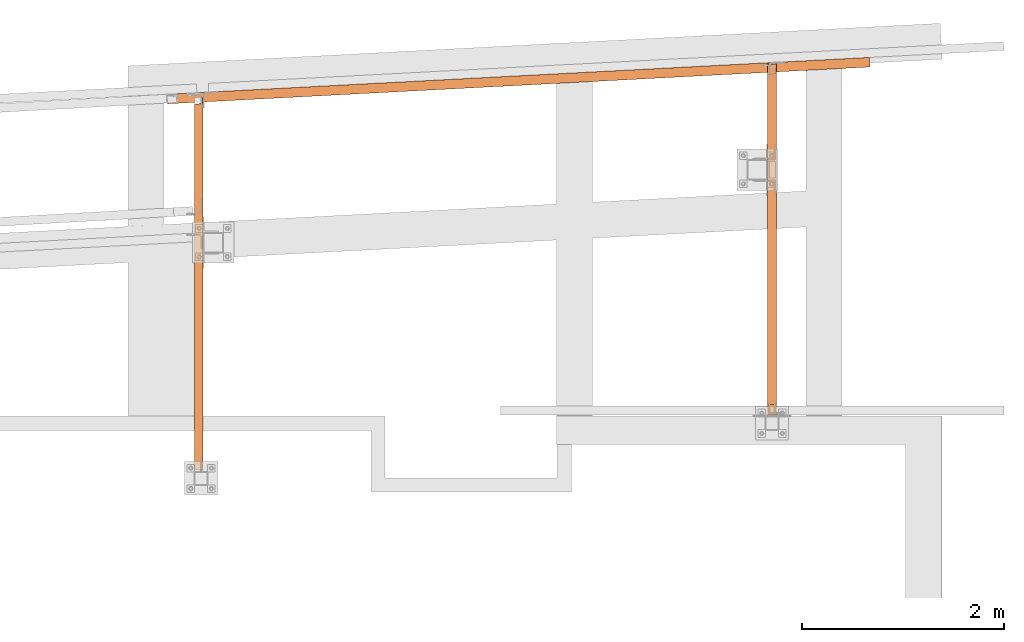
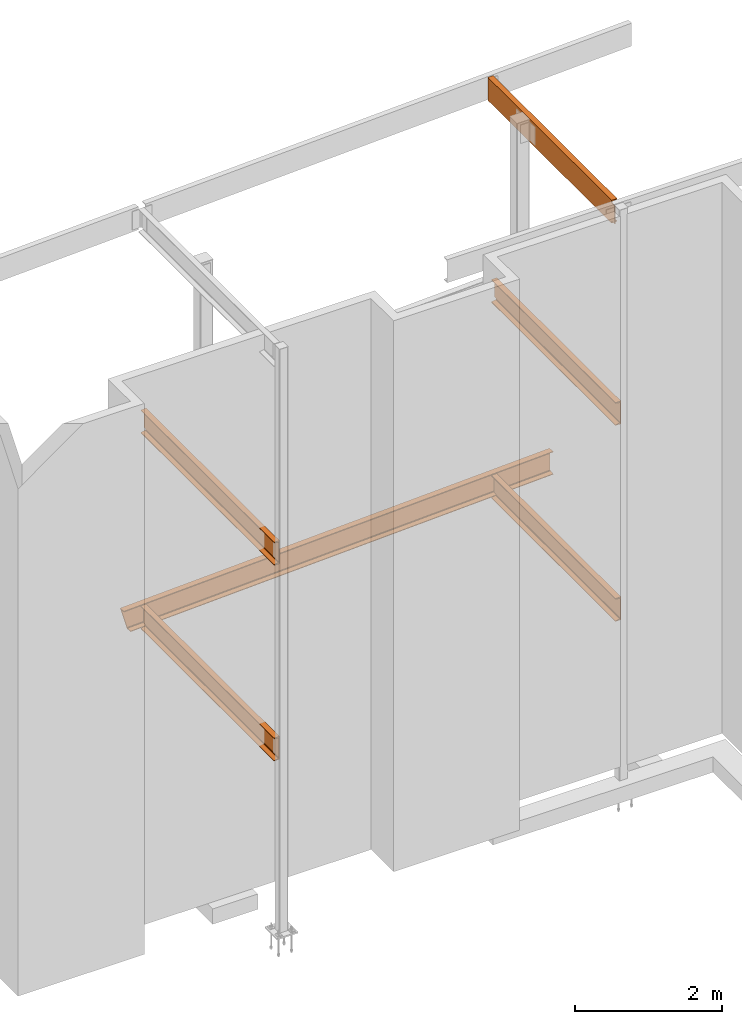
# One storey, part 20 of 89: 6 proxies.
"""IFC4 building model written with IfcOpenShell, lengths in feet."""

from ifc_helpers import new_model, entity, si_unit, converted_unit, derived_unit, direction, frame, origin, place, context, subcontext, project, spatial, faceted_brep, source, transform, mapped, material, constituent, constituent_set, type_object, type_shapes, element, save


model = new_model("IFC4")

# Units and contexts
model_context = context("Model", 3, precision=0.0001, world=origin(), true_north=direction((6.12303176911189e-17, 1.0)))
body_context = subcontext(model_context, "Body", "Model", "MODEL_VIEW")
ifc_project = project(units=[converted_unit("LENGTHUNIT", "FOOT", entity("IfcRatioMeasure", 0.3048), si_unit("LENGTHUNIT", "METRE"), dimensions=[1, 0, 0, 0, 0, 0, 0]), converted_unit("AREAUNIT", "SQUARE FOOT", entity("IfcRatioMeasure", 0.09290304), si_unit("AREAUNIT", "SQUARE_METRE"), dimensions=[2, 0, 0, 0, 0, 0, 0]), converted_unit("VOLUMEUNIT", "CUBIC FOOT", entity("IfcRatioMeasure", 0.028316846592), si_unit("VOLUMEUNIT", "CUBIC_METRE"), dimensions=[3, 0, 0, 0, 0, 0, 0]), si_unit("PLANEANGLEUNIT", "RADIAN"), si_unit("MASSUNIT", "GRAM", prefix="KILO"), derived_unit("MASSDENSITYUNIT", [(si_unit("MASSUNIT", "GRAM", prefix="KILO"), 1), (si_unit("LENGTHUNIT", "METRE"), -3)]), derived_unit("MOMENTOFINERTIAUNIT", [(si_unit("LENGTHUNIT", "METRE"), 4)]), si_unit("TIMEUNIT", "SECOND"), si_unit("FREQUENCYUNIT", "HERTZ"), si_unit("THERMODYNAMICTEMPERATUREUNIT", "DEGREE_CELSIUS"), derived_unit("THERMALTRANSMITTANCEUNIT", [(si_unit("MASSUNIT", "GRAM", prefix="KILO"), 1), (si_unit("THERMODYNAMICTEMPERATUREUNIT", "KELVIN"), -1), (si_unit("TIMEUNIT", "SECOND"), -3)]), derived_unit("VOLUMETRICFLOWRATEUNIT", [(si_unit("LENGTHUNIT", "METRE"), 3), (si_unit("TIMEUNIT", "SECOND"), -1)]), si_unit("ELECTRICCURRENTUNIT", "AMPERE"), si_unit("ELECTRICVOLTAGEUNIT", "VOLT"), si_unit("POWERUNIT", "WATT"), si_unit("FORCEUNIT", "NEWTON"), si_unit("ILLUMINANCEUNIT", "LUX"), si_unit("LUMINOUSFLUXUNIT", "LUMEN"), si_unit("LUMINOUSINTENSITYUNIT", "CANDELA"), derived_unit("USERDEFINED", [(si_unit("MASSUNIT", "GRAM", prefix="KILO"), -1), (si_unit("LENGTHUNIT", "METRE"), -2), (si_unit("TIMEUNIT", "SECOND"), 3), (si_unit("LUMINOUSFLUXUNIT", "LUMEN"), 1)]), derived_unit("LINEARVELOCITYUNIT", [(si_unit("LENGTHUNIT", "METRE"), 1), (si_unit("TIMEUNIT", "SECOND"), -1)]), si_unit("PRESSUREUNIT", "PASCAL"), derived_unit("USERDEFINED", [(si_unit("LENGTHUNIT", "METRE"), -2), (si_unit("MASSUNIT", "GRAM", prefix="KILO"), 1), (si_unit("TIMEUNIT", "SECOND"), -2)]), derived_unit("LINEARFORCEUNIT", [(si_unit("MASSUNIT", "GRAM", prefix="KILO"), 1), (si_unit("LENGTHUNIT", "METRE"), 1), (si_unit("TIMEUNIT", "SECOND"), -2), (si_unit("LENGTHUNIT", "METRE"), -1)]), derived_unit("PLANARFORCEUNIT", [(si_unit("MASSUNIT", "GRAM", prefix="KILO"), 1), (si_unit("LENGTHUNIT", "METRE"), 1), (si_unit("TIMEUNIT", "SECOND"), -2), (si_unit("LENGTHUNIT", "METRE"), -2)])], contexts=[model_context])

# Site, building, storey
site_placement = place(None, origin())
site = spatial("IfcSite", under=ifc_project, at=site_placement, CompositionType="ELEMENT")
building_placement = place(site_placement, frame((-472.238160486, -49.138065117, 0.0)))
building = spatial("IfcBuilding", under=site, at=building_placement, CompositionType="ELEMENT")
storey_placement = place(building_placement, origin())
storey = spatial("IfcBuildingStorey", under=building, at=storey_placement, Name="Level 1", CompositionType="ELEMENT", Elevation=0.0)

# Proxies
ifc_material_1 = material(Name="Color 7720", Category="Materials")
ifc_material_2 = material()
ifc_constituent_1 = constituent(ifc_material_2)
ifc_constituent_2 = constituent(ifc_material_1, Name="Color 7720", Category="Materials")
ifc_constituent_set_1 = constituent_set(constituents=[ifc_constituent_1, ifc_constituent_2])
building_element_proxy_type_1 = type_object("IfcBuildingElementProxyType", Name="17B1", PredefinedType="NOTDEFINED", material=ifc_constituent_set_1)
shared_shape_1 = source(origin(), body_context, "Body", "Brep", [
    faceted_brep([(0.0, 0.309575155774041, 1.25), (0.357523018910797, 0.328312143237781, 0.0), (0.373747165346117, 0.0187369874638534, 0.0), (0.364220956214638, 0.0182377399981988, 0.0333062789933916), (0.343602348434274, 0.223617862109904, 0.0676680457191132), (0.340924744883921, 0.240912802348817, 0.0738437414016779), (0.336807802828389, 0.254938044365076, 0.085635454312385), (0.331754718383309, 0.263979343166852, 0.101601934112377), (0.326383108321011, 0.26693161969888, 0.119791666666666), (0.0373853347014688, 0.251785888165614, 1.13020833333333), (0.0323517478101394, 0.248288298368493, 1.14839806588763), (0.0282714177600951, 0.238768337595729, 1.16436454568762), (0.0256430657388478, 0.224389589696102, 1.17615625859832), (0.0247879439063468, 0.206909507165051, 1.18233195428089), (0.0257503555668563, 0.000499247465654662, 1.21669372100661), (0.0162241464353201, 0.0, 1.25), (22.8188993104869, 1.19503756706081, 1.25), (22.8188993104869, 1.19503756706081, 1.2166937210066), (22.8081088007665, 1.40093275796642, 1.18233195428088), (22.8071975599075, 1.41832026935128, 1.17615625859831), (22.8064532648904, 1.43252226430934, 1.16436454568762), (22.8059668876929, 1.44180289409644, 1.14839806588763), (22.8057978761074, 1.44502782726101, 1.13020833333333), (22.8057978761074, 1.44502782726101, 0.119791666666671), (22.8059668876929, 1.44180289409644, 0.101601934112372), (22.8064532648904, 1.43252226430934, 0.0856354543123814), (22.8071975599075, 1.41832026935128, 0.0738437414016921), (22.8081088007665, 1.40093275796642, 0.0676680457191221), (22.8188993104869, 1.19503756706081, 0.0333062789934022), (22.8188993104869, 1.19503756706081, 0.0), (22.8026751640516, 1.50461272283474, 0.0), (22.8026751640516, 1.50461272283474, 1.25)], [[[0, 1, 2, 3, 4, 5, 6, 7, 8, 9, 10, 11, 12, 13, 14, 15]], [[16, 17, 18, 19, 20, 21, 22, 23, 24, 25, 26, 27, 28, 29, 30, 31]], [[30, 1, 0, 31]], [[29, 2, 1, 30]], [[28, 3, 2, 29]], [[27, 4, 3, 28]], [[26, 5, 4, 27]], [[25, 6, 5, 26]], [[24, 7, 6, 25]], [[23, 8, 7, 24]], [[22, 9, 8, 23]], [[21, 10, 9, 22]], [[20, 11, 10, 21]], [[19, 12, 11, 20]], [[18, 13, 12, 19]], [[17, 14, 13, 18]], [[16, 15, 14, 17]], [[31, 0, 15, 16]]]),
])
type_shapes(building_element_proxy_type_1, [shared_shape_1])
proxy_1_placement = place(building_placement, frame((306.666666666667, 1018.1412206105, 8.35416666666667)))
element("IfcBuildingElementProxy", 1, at=proxy_1_placement, inside=storey, type_object=building_element_proxy_type_1, material=ifc_material_1, Name="17B1:17B1", ObjectType="17B1:17B1", PredefinedType="NOTDEFINED", context=body_context, shape_type="MappedRepresentation", body=[
    mapped(shared_shape_1, transform((0.0, 0.0, 0.0), scale=1.0)),
])
ifc_constituent_3 = constituent(ifc_material_2)
ifc_constituent_4 = constituent(ifc_material_1, Name="Color 7720", Category="Materials")
ifc_constituent_set_2 = constituent_set(constituents=[ifc_constituent_3, ifc_constituent_4])
building_element_proxy_type_2 = type_object("IfcBuildingElementProxyType", Name="c749", PredefinedType="NOTDEFINED", material=ifc_constituent_set_2)
shared_shape_2 = source(origin(), body_context, "Body", "Brep", [
    faceted_brep([(0.0, 0.0, 1.25), (0.0, 0.0, 1.21666594419212), (0.205817018106757, 0.0, 1.18236429742145), (0.223239195075223, 0.0, 1.17618476966831), (0.237469504634021, 0.0, 1.16438573990164), (0.24676863726728, 0.0, 1.14840935276805), (0.249999999999943, 0.0, 1.13020833333334), (0.249999999999943, 0.0, 0.119791666666673), (0.24676863726728, 0.0, 0.101590647231953), (0.237469504634021, 0.0, 0.0856142600983727), (0.223239195075223, 0.0, 0.073815230331693), (0.205817018106757, 0.0, 0.0676357025785528), (0.0, 0.0, 0.0333340558078827), (0.0, 0.0, 0.0), (0.283333333333303, 0.0, 0.0), (0.283333333333303, 0.0, 1.25), (0.249999999999943, 11.2792629997535, 0.125000000000004), (0.249999999999943, 11.2792629997535, 1.125), (0.283333333333303, 11.2792629997535, 1.125), (0.283333333333303, 11.2792629997535, 0.125000000000004), (0.0, 11.0664753261987, 1.21666594419212), (0.0, 11.0664753261987, 1.25), (0.184374999999989, 11.0761379997535, 1.18593784317542), (0.205817018106757, 11.0761379997535, 1.18236429742146), (0.223239195075223, 11.0761379997535, 1.17618476966831), (0.237469504634021, 11.0765917042962, 1.16438573990166), (0.234718575567001, 11.0761379997535, 1.16666666666671), (0.24676863726728, 11.0808546290905, 1.14840935276807), (0.24542282713287, 11.0793096858989, 1.15072152365148), (0.249999999999943, 11.098811465487, 1.13020833333334), (0.248758027692929, 11.0883418838708, 1.13720388411723), (0.249999999999943, 11.101859523405, 0.121828313854644), (0.249999999999943, 11.098811465487, 0.119791666666673), (0.249999999999943, 11.101859523405, 1.12817168614537), (0.249999999999943, 11.1178046664203, 1.125), (0.249999999999943, 11.1178046664203, 0.125000000000004), (0.24676863726728, 11.0808546290905, 0.101590647231946), (0.248758027692929, 11.0883418838708, 0.11279611588277), (0.237469504634021, 11.0765917042962, 0.0856142600983567), (0.24542282713287, 11.0793096858989, 0.0992784763485322), (0.223239195075223, 11.0761379997535, 0.0738152303316753), (0.234718575567001, 11.0761379997535, 0.0833333333332966), (0.205817018106757, 11.0761379997535, 0.0676357025785528), (0.0, 11.0664753261987, 0.033334055807881), (0.184374999999989, 11.0761379997535, 0.0640621568245905), (0.0, 11.0664753261987, 0.0), (0.184374999999989, 11.0761379997535, 0.0), (0.283333333333303, 11.0761379997535, 0.0), (0.283333333333246, 11.0793096858989, 0.0992784763485535), (0.283333333333246, 11.0883418838708, 0.112796115882773), (0.283333333333246, 11.101859523405, 0.121828313854644), (0.283333333333246, 11.1178046664203, 0.125000000000004), (0.283333333333246, 11.1178046664203, 1.125), (0.283333333333246, 11.101859523405, 1.12817168614537), (0.283333333333246, 11.0883418838708, 1.13720388411723), (0.283333333333246, 11.0793096858989, 1.15072152365146), (0.283333333333246, 11.0761379997535, 1.16666666666667), (0.283333333333246, 11.0761379997535, 1.25), (0.283333333333246, 11.0761379997535, 0.0833333333333339), (0.184374999999989, 11.0761379997535, 1.25000000000001)], [[[0, 1, 2, 3, 4, 5, 6, 7, 8, 9, 10, 11, 12, 13, 14, 15]], [[16, 17, 18, 19]], [[20, 1, 0, 21]], [[22, 23, 2, 1, 20]], [[24, 3, 2, 23]], [[25, 4, 3, 24, 26]], [[27, 5, 4, 25, 28]], [[29, 6, 5, 27, 30]], [[31, 32, 7, 6, 29, 33, 34, 17, 16, 35]], [[36, 8, 7, 32, 37]], [[38, 9, 8, 36, 39]], [[40, 10, 9, 38, 41]], [[42, 11, 10, 40]], [[43, 12, 11, 42, 44]], [[45, 13, 12, 43]], [[46, 47, 14, 13, 45]], [[48, 49, 50, 51, 19, 18, 52, 53, 54, 55, 56, 57, 15, 14, 47, 58]], [[21, 0, 15, 57, 59]], [[59, 57, 56, 26, 24, 23, 22]], [[26, 56, 55, 28, 25]], [[28, 55, 54, 30, 27]], [[30, 54, 53, 33, 29]], [[33, 53, 52, 34]], [[17, 34, 52, 18]], [[59, 22, 20, 21]], [[19, 51, 35, 16]], [[50, 31, 35, 51]], [[31, 50, 49, 37, 32]], [[37, 49, 48, 39, 36]], [[39, 48, 58, 41, 38]], [[44, 46, 47, 58, 41, 40, 42]], [[45, 43, 44, 46]]]),
])
type_shapes(building_element_proxy_type_2, [shared_shape_2])
proxy_2_placement = place(building_placement, frame((326.166666666667, 1008.04166666666, 8.35416666666666)))
element("IfcBuildingElementProxy", 2, at=proxy_2_placement, inside=storey, type_object=building_element_proxy_type_2, material=ifc_material_1, Name="c749:c749", ObjectType="c749:c749", PredefinedType="NOTDEFINED", context=body_context, shape_type="MappedRepresentation", body=[
    mapped(shared_shape_2, transform((0.0, 0.0, 0.0), scale=1.0)),
])
ifc_constituent_5 = constituent(ifc_material_2)
ifc_constituent_6 = constituent(ifc_material_1, Name="Color 7720", Category="Materials")
ifc_constituent_set_3 = constituent_set(constituents=[ifc_constituent_5, ifc_constituent_6])
building_element_proxy_type_3 = type_object("IfcBuildingElementProxyType", Name="c748", PredefinedType="NOTDEFINED", material=ifc_constituent_set_3)
shared_shape_3 = source(origin(), body_context, "Body", "Brep", [
    faceted_brep([(0.0, 0.0, 1.25), (0.0, 0.0, 1.21666594419212), (0.205817018106814, 0.0, 1.18236429742145), (0.22323919507528, 0.0, 1.17618476966831), (0.237469504634078, 0.0, 1.16438573990164), (0.246768637267337, 0.0, 1.14840935276805), (0.25, 0.0, 1.13020833333334), (0.25, 0.0, 0.119791666666673), (0.246768637267337, 0.0, 0.101590647231953), (0.237469504634078, 0.0, 0.0856142600983727), (0.22323919507528, 0.0, 0.073815230331693), (0.205817018106814, 0.0, 0.0676357025785528), (0.0, 0.0, 0.0333340558078827), (0.0, 0.0, 0.0), (0.28333333333336, 0.0, 0.0), (0.28333333333336, 0.0, 1.25), (0.25, 12.0952715087674, 0.125000000000004), (0.25, 12.0952715087674, 1.125), (0.28333333333336, 12.0952715087674, 1.125), (0.28333333333336, 12.0952715087674, 0.125000000000004), (0.0, 11.8824838352124, 1.21666594419212), (0.0, 11.8824838352124, 1.25), (0.184375000000045, 11.8921465087674, 1.18593784317542), (0.205817018106814, 11.8921465087674, 1.18236429742146), (0.22323919507528, 11.8921465087674, 1.17618476966831), (0.237469504634078, 11.8926002133099, 1.16438573990166), (0.234718575567058, 11.8921465087674, 1.16666666666671), (0.246768637267337, 11.8968631381042, 1.14840935276807), (0.245422827132927, 11.8953181949128, 1.15072152365148), (0.25, 11.9148199745007, 1.13020833333334), (0.248758027692986, 11.9043503928847, 1.13720388411723), (0.250000000000057, 11.9178680324187, 0.121828313854644), (0.250000000000057, 11.9148199745007, 0.119791666666673), (0.250000000000057, 11.9178680324187, 1.12817168614537), (0.250000000000057, 11.933813175434, 1.125), (0.250000000000057, 11.933813175434, 0.125000000000004), (0.246768637267337, 11.8968631381042, 0.101590647231946), (0.248758027692986, 11.9043503928847, 0.11279611588277), (0.237469504634078, 11.8926002133099, 0.0856142600983567), (0.245422827132927, 11.8953181949128, 0.0992784763485322), (0.22323919507528, 11.8921465087674, 0.0738152303316753), (0.234718575567058, 11.8921465087674, 0.0833333333332966), (0.205817018106814, 11.8921465087674, 0.0676357025785528), (0.0, 11.8824838352124, 0.033334055807881), (0.184375000000045, 11.8921465087674, 0.0640621568245905), (0.0, 11.8824838352124, 0.0), (0.184375000000045, 11.8921465087674, 0.0), (0.28333333333336, 11.8921465087674, 0.0), (0.283333333333417, 11.8953181949128, 0.0992784763485535), (0.283333333333417, 11.9043503928847, 0.112796115882773), (0.283333333333417, 11.9178680324187, 0.121828313854644), (0.283333333333417, 11.933813175434, 0.125000000000004), (0.283333333333417, 11.933813175434, 1.125), (0.283333333333417, 11.9178680324187, 1.12817168614537), (0.283333333333417, 11.9043503928847, 1.13720388411723), (0.283333333333417, 11.8953181949128, 1.15072152365146), (0.283333333333417, 11.8921465087674, 1.16666666666667), (0.283333333333417, 11.8921465087674, 1.25), (0.283333333333417, 11.8921465087674, 0.0833333333333339), (0.184375000000045, 11.8921465087674, 1.25000000000001)], [[[0, 1, 2, 3, 4, 5, 6, 7, 8, 9, 10, 11, 12, 13, 14, 15]], [[16, 17, 18, 19]], [[20, 1, 0, 21]], [[22, 23, 2, 1, 20]], [[24, 3, 2, 23]], [[25, 4, 3, 24, 26]], [[27, 5, 4, 25, 28]], [[29, 6, 5, 27, 30]], [[31, 32, 7, 6, 29, 33, 34, 17, 16, 35]], [[36, 8, 7, 32, 37]], [[38, 9, 8, 36, 39]], [[40, 10, 9, 38, 41]], [[42, 11, 10, 40]], [[43, 12, 11, 42, 44]], [[45, 13, 12, 43]], [[46, 47, 14, 13, 45]], [[48, 49, 50, 51, 19, 18, 52, 53, 54, 55, 56, 57, 15, 14, 47, 58]], [[21, 0, 15, 57, 59]], [[59, 57, 56, 26, 24, 23, 22]], [[26, 56, 55, 28, 25]], [[28, 55, 54, 30, 27]], [[30, 54, 53, 33, 29]], [[33, 53, 52, 34]], [[17, 34, 52, 18]], [[59, 22, 20, 21]], [[19, 51, 35, 16]], [[50, 31, 35, 51]], [[31, 50, 49, 37, 32]], [[37, 49, 48, 39, 36]], [[39, 48, 58, 41, 38]], [[44, 46, 47, 58, 41, 40, 42]], [[45, 43, 44, 46]]]),
])
type_shapes(building_element_proxy_type_3, [shared_shape_3])
proxy_3_placement = place(building_placement, frame((307.55, 1006.25, 8.35416666666666)))
element("IfcBuildingElementProxy", 3, at=proxy_3_placement, inside=storey, type_object=building_element_proxy_type_3, material=ifc_material_1, Name="c748:c748", ObjectType="c748:c748", PredefinedType="NOTDEFINED", context=body_context, shape_type="MappedRepresentation", body=[
    mapped(shared_shape_3, transform((0.0, 0.0, 0.0), scale=1.0)),
])
ifc_constituent_7 = constituent(ifc_material_2)
ifc_constituent_8 = constituent(ifc_material_1, Name="Color 7720", Category="Materials")
ifc_constituent_set_4 = constituent_set(constituents=[ifc_constituent_7, ifc_constituent_8])
building_element_proxy_type_4 = type_object("IfcBuildingElementProxyType", Name="c750", PredefinedType="NOTDEFINED", material=ifc_constituent_set_4)
shared_shape_4 = source(origin(), body_context, "Body", "Brep", [
    faceted_brep([(0.0, 0.0, 1.25), (0.0, 0.0, 1.21666594419212), (0.205817018106757, 0.0, 1.18236429742145), (0.223239195075223, 0.0, 1.17618476966831), (0.237469504634021, 0.0, 1.16438573990164), (0.24676863726728, 0.0, 1.14840935276806), (0.249999999999943, 0.0, 1.13020833333334), (0.249999999999943, 0.0, 0.119791666666675), (0.24676863726728, 0.0, 0.101590647231955), (0.237469504634021, 0.0, 0.0856142600983745), (0.223239195075223, 0.0, 0.073815230331693), (0.205817018106757, 0.0, 0.0676357025785528), (0.0, 0.0, 0.0333340558078845), (0.0, 0.0, 0.0), (0.283333333333303, 0.0, 0.0), (0.283333333333303, 0.0, 1.25), (0.249999999999943, 11.219927776912, 0.125000000000004), (0.249999999999943, 11.219927776912, 1.125), (0.283333333333303, 11.219927776912, 1.125), (0.283333333333303, 11.219927776912, 0.125000000000004), (0.0, 11.0644317700238, 1.21666594419212), (0.0, 11.0644317700238, 1.25), (0.184374999999989, 11.0740944435787, 1.18593784317542), (0.205817018106757, 11.0740944435787, 1.18236429742145), (0.223239195075223, 11.0740944435787, 1.17618476966831), (0.237469504634021, 11.0745481481213, 1.16438573990166), (0.234718575567058, 11.0740944435787, 1.16666666666669), (0.24676863726728, 11.0788110729155, 1.14840935276807), (0.24542282713287, 11.0772661297241, 1.15072152365148), (0.249999999999943, 11.0967679093121, 1.13020833333334), (0.248758027692929, 11.086298327696, 1.13720388411724), (0.249999999999943, 11.09981596723, 0.121828313854643), (0.249999999999943, 11.0967679093121, 0.119791666666675), (0.249999999999943, 11.09981596723, 1.12817168614536), (0.249999999999943, 11.1157611102453, 1.125), (0.249999999999943, 11.1157611102453, 0.125000000000004), (0.24676863726728, 11.0788110729155, 0.101590647231948), (0.248758027692929, 11.086298327696, 0.112796115882766), (0.237469504634021, 11.0745481481213, 0.0856142600983567), (0.24542282713287, 11.0772661297241, 0.0992784763485268), (0.223239195075223, 11.0740944435787, 0.0738152303316753), (0.234718575567001, 11.0740944435787, 0.0833333333332966), (0.205817018106757, 11.0740944435787, 0.0676357025785528), (0.0, 11.0644317700238, 0.0333340558078845), (0.184374999999989, 11.0740944435787, 0.0640621568245905), (0.0, 11.0644317700238, 0.0), (0.184374999999989, 11.0740944435787, 0.0), (0.283333333333303, 11.0740944435787, 0.0), (0.283333333333246, 11.0772661297241, 0.099278476348541), (0.283333333333246, 11.086298327696, 0.112796115882773), (0.283333333333246, 11.09981596723, 0.121828313854643), (0.283333333333246, 11.1157611102453, 0.125), (0.283333333333246, 11.1157611102453, 1.125), (0.283333333333246, 11.09981596723, 1.12817168614536), (0.283333333333246, 11.086298327696, 1.13720388411723), (0.283333333333246, 11.0772661297241, 1.15072152365146), (0.283333333333246, 11.0740944435787, 1.16666666666667), (0.283333333333246, 11.0740944435787, 1.25), (0.283333333333246, 11.0740944435787, 0.0833333333333286), (0.184374999999989, 11.0740944435787, 1.25000000000001)], [[[0, 1, 2, 3, 4, 5, 6, 7, 8, 9, 10, 11, 12, 13, 14, 15]], [[16, 17, 18, 19]], [[20, 1, 0, 21]], [[22, 23, 2, 1, 20]], [[24, 3, 2, 23]], [[25, 4, 3, 24, 26]], [[27, 5, 4, 25, 28]], [[29, 6, 5, 27, 30]], [[31, 32, 7, 6, 29, 33, 34, 17, 16, 35]], [[36, 8, 7, 32, 37]], [[38, 9, 8, 36, 39]], [[40, 10, 9, 38, 41]], [[42, 11, 10, 40]], [[43, 12, 11, 42, 44]], [[45, 13, 12, 43]], [[46, 47, 14, 13, 45]], [[48, 49, 50, 51, 19, 18, 52, 53, 54, 55, 56, 57, 15, 14, 47, 58]], [[21, 0, 15, 57, 59]], [[59, 57, 56, 26, 24, 23, 22]], [[26, 56, 55, 28, 25]], [[28, 55, 54, 30, 27]], [[30, 54, 53, 33, 29]], [[33, 53, 52, 34]], [[17, 34, 52, 18]], [[59, 22, 20, 21]], [[19, 51, 35, 16]], [[50, 31, 35, 51]], [[31, 50, 49, 37, 32]], [[37, 49, 48, 39, 36]], [[39, 48, 58, 41, 38]], [[44, 46, 47, 58, 41, 40, 42]], [[45, 43, 44, 46]]]),
])
type_shapes(building_element_proxy_type_4, [shared_shape_4])
proxy_4_placement = place(building_placement, frame((326.166666666667, 1008.04166666666, 19.0208333333333)))
element("IfcBuildingElementProxy", 4, at=proxy_4_placement, inside=storey, type_object=building_element_proxy_type_4, material=ifc_material_1, Name="c750:c750", ObjectType="c750:c750", PredefinedType="NOTDEFINED", context=body_context, shape_type="MappedRepresentation", body=[
    mapped(shared_shape_4, transform((0.0, 0.0, 0.0), scale=1.0)),
])
ifc_constituent_9 = constituent(ifc_material_2)
ifc_constituent_10 = constituent(ifc_material_1, Name="Color 7720", Category="Materials")
ifc_constituent_set_5 = constituent_set(constituents=[ifc_constituent_9, ifc_constituent_10])
building_element_proxy_type_5 = type_object("IfcBuildingElementProxyType", Name="c755", PredefinedType="NOTDEFINED", material=ifc_constituent_set_5)
shared_shape_5 = source(origin(), body_context, "Body", "Brep", [
    faceted_brep([(0.0, 0.0, 1.25), (0.0, 0.0, 1.21666594419212), (0.205817018106814, 0.0, 1.18236429742145), (0.22323919507528, 0.0, 1.17618476966831), (0.237469504634078, 0.0, 1.16438573990164), (0.246768637267337, 0.0, 1.14840935276806), (0.25, 0.0, 1.13020833333334), (0.25, 0.0, 0.119791666666675), (0.246768637267337, 0.0, 0.101590647231955), (0.237469504634078, 0.0, 0.0856142600983745), (0.22323919507528, 0.0, 0.073815230331693), (0.205817018106814, 0.0, 0.0676357025785528), (0.0, 0.0, 0.0333340558078845), (0.0, 0.0, 0.0), (0.28333333333336, 0.0, 0.0), (0.28333333333336, 0.0, 1.25), (0.25, 12.0463529525928, 0.125000000000004), (0.25, 12.0463529525928, 1.125), (0.28333333333336, 12.0463529525928, 1.125), (0.28333333333336, 12.0463529525928, 0.125000000000004), (0.0, 11.8856486123713, 1.21666594419212), (0.0, 11.8856486123713, 1.25), (0.184375000000045, 11.895311285926, 1.18593784317542), (0.205817018106814, 11.895311285926, 1.18236429742145), (0.22323919507528, 11.895311285926, 1.17618476966831), (0.237469504634078, 11.8957649904686, 1.16438573990166), (0.234718575567115, 11.895311285926, 1.16666666666669), (0.246768637267337, 11.900027915263, 1.14840935276807), (0.245422827132927, 11.8984829720714, 1.15072152365148), (0.25, 11.9179847516594, 1.13020833333334), (0.248758027692986, 11.9075151700433, 1.13720388411724), (0.250000000000057, 11.9210328095775, 0.121828313854643), (0.250000000000057, 11.9179847516594, 0.119791666666675), (0.250000000000057, 11.9210328095775, 1.12817168614536), (0.250000000000057, 11.9369779525928, 1.125), (0.250000000000057, 11.9369779525928, 0.125000000000004), (0.246768637267337, 11.900027915263, 0.101590647231948), (0.248758027692986, 11.9075151700433, 0.112796115882766), (0.237469504634078, 11.8957649904686, 0.0856142600983567), (0.245422827132927, 11.8984829720714, 0.0992784763485268), (0.22323919507528, 11.895311285926, 0.0738152303316753), (0.234718575567058, 11.895311285926, 0.0833333333332966), (0.205817018106814, 11.895311285926, 0.0676357025785528), (0.0, 11.8856486123713, 0.0333340558078845), (0.184375000000045, 11.895311285926, 0.0640621568245905), (0.0, 11.8856486123713, 0.0), (0.184375000000045, 11.895311285926, 0.0), (0.28333333333336, 11.895311285926, 0.0), (0.283333333333417, 11.8984829720714, 0.099278476348541), (0.283333333333417, 11.9075151700433, 0.11279611588277), (0.283333333333417, 11.9210328095775, 0.121828313854639), (0.283333333333417, 11.9369779525928, 0.125), (0.283333333333417, 11.9369779525928, 1.125), (0.283333333333417, 11.9210328095775, 1.12817168614536), (0.283333333333417, 11.9075151700433, 1.13720388411723), (0.283333333333417, 11.8984829720714, 1.15072152365146), (0.283333333333417, 11.895311285926, 1.16666666666667), (0.283333333333417, 11.895311285926, 1.25), (0.283333333333417, 11.895311285926, 0.0833333333333286), (0.184375000000045, 11.895311285926, 1.25000000000001)], [[[0, 1, 2, 3, 4, 5, 6, 7, 8, 9, 10, 11, 12, 13, 14, 15]], [[16, 17, 18, 19]], [[20, 1, 0, 21]], [[22, 23, 2, 1, 20]], [[24, 3, 2, 23]], [[25, 4, 3, 24, 26]], [[27, 5, 4, 25, 28]], [[29, 6, 5, 27, 30]], [[31, 32, 7, 6, 29, 33, 34, 17, 16, 35]], [[36, 8, 7, 32, 37]], [[38, 9, 8, 36, 39]], [[40, 10, 9, 38, 41]], [[42, 11, 10, 40]], [[43, 12, 11, 42, 44]], [[45, 13, 12, 43]], [[46, 47, 14, 13, 45]], [[48, 49, 50, 51, 19, 18, 52, 53, 54, 55, 56, 57, 15, 14, 47, 58]], [[21, 0, 15, 57, 59]], [[59, 57, 56, 26, 24, 23, 22]], [[26, 56, 55, 28, 25]], [[28, 55, 54, 30, 27]], [[30, 54, 53, 33, 29]], [[33, 53, 52, 34]], [[17, 34, 52, 18]], [[59, 22, 20, 21]], [[19, 51, 35, 16]], [[50, 31, 35, 51]], [[31, 50, 49, 37, 32]], [[37, 49, 48, 39, 36]], [[39, 48, 58, 41, 38]], [[44, 46, 47, 58, 41, 40, 42]], [[45, 43, 44, 46]]]),
])
type_shapes(building_element_proxy_type_5, [shared_shape_5])
proxy_5_placement = place(building_placement, frame((307.55, 1006.25, 19.0208333333333)))
element("IfcBuildingElementProxy", 5, at=proxy_5_placement, inside=storey, type_object=building_element_proxy_type_5, material=ifc_material_1, Name="c755:c755", ObjectType="c755:c755", PredefinedType="NOTDEFINED", context=body_context, shape_type="MappedRepresentation", body=[
    mapped(shared_shape_5, transform((0.0, 0.0, 0.0), scale=1.0)),
])
ifc_constituent_11 = constituent(ifc_material_2)
ifc_constituent_12 = constituent(ifc_material_1, Name="Color 7720", Category="Materials")
ifc_constituent_set_6 = constituent_set(constituents=[ifc_constituent_11, ifc_constituent_12])
building_element_proxy_type_6 = type_object("IfcBuildingElementProxyType", Name="c777", PredefinedType="NOTDEFINED", material=ifc_constituent_set_6)
shared_shape_6 = source(origin(), body_context, "Body", "Brep", [
    faceted_brep([(0.0333333333333599, 0.0, 1.125), (0.0, 0.0, 1.125), (0.0, 0.0, 0.125000000000004), (0.0333333333333599, 0.0, 0.125000000000004), (0.28333333333336, 11.316684068312, 1.25), (0.28333333333336, 11.316684068312, 1.21666594419212), (0.0775163152265463, 11.316684068312, 1.18236429742145), (0.06009413825808, 11.316684068312, 1.17618476966831), (0.0458638286992823, 11.316684068312, 1.16438573990164), (0.0365646960660229, 11.316684068312, 1.14840935276806), (0.0333333333333599, 11.316684068312, 1.13020833333334), (0.0333333333333599, 11.316684068312, 0.119791666666675), (0.0365646960660229, 11.316684068312, 0.101590647231955), (0.0458638286992823, 11.316684068312, 0.0856142600983745), (0.06009413825808, 11.316684068312, 0.073815230331693), (0.0775163152265463, 11.316684068312, 0.0676357025785528), (0.28333333333336, 11.316684068312, 0.0333340558078845), (0.28333333333336, 11.316684068312, 0.0), (0.0, 11.316684068312, 0.0), (0.0, 11.316684068312, 1.25), (0.0, 0.267661647187879, 0.099278476348541), (0.0, 0.25862944921596, 0.112796115882773), (0.0, 0.245111809681816, 0.121828313854639), (0.0, 0.229166666666629, 0.125), (0.0, 0.229166666666629, 1.125), (0.0, 0.245111809681816, 1.12817168614537), (0.0, 0.25862944921596, 1.13720388411723), (0.0, 0.267661647187879, 1.15072152365146), (0.0, 0.270833333333258, 1.16666666666667), (0.0, 0.270833333333258, 1.25), (0.0, 0.270833333333258, 0.0), (0.0, 0.270833333333258, 0.0833333333333286), (0.0750833333333389, 0.270833333333258, 0.0), (0.28333333333336, 0.270833333333258, 0.0), (0.28333333333336, 0.270833333333258, 0.0333340558078845), (0.0775163152265463, 0.270833333333258, 0.0676357025785528), (0.06009413825808, 0.270833333333258, 0.0738152303317108), (0.0750833333333389, 0.270833333333258, 0.0684986647192503), (0.0458638286992823, 0.270379628790693, 0.0856142600983958), (0.0486147577663019, 0.270833333333258, 0.0833333333333357), (0.0365646960660229, 0.266116703996317, 0.10159064723198), (0.0379105062004328, 0.267661647187879, 0.0992784763485695), (0.0333333333334167, 0.248159867599838, 0.119791666666679), (0.0345753056404305, 0.25862944921596, 0.112796115882777), (0.0333333333333599, 0.245111809681816, 0.121828313854643), (0.0333333333333599, 0.248159867599838, 1.13020833333334), (0.0333333333333599, 0.245111809681816, 1.12817168614537), (0.0333333333333599, 0.229166666666629, 1.125), (0.0333333333333599, 0.229166666666629, 0.125000000000004), (0.0365646960660797, 0.266116703996317, 1.14840935276806), (0.0345753056404305, 0.25862944921596, 1.13720388411723), (0.0458638286992823, 0.270379628790693, 1.16438573990161), (0.0379105062004328, 0.267661647187879, 1.15072152365144), (0.06009413825808, 0.270833333333258, 1.17618476966829), (0.0486147577663019, 0.270833333333258, 1.16666666666667), (0.0750833333333389, 0.270833333333258, 1.18150133528075), (0.0775163152265463, 0.270833333333258, 1.18236429742143), (0.28333333333336, 0.270833333333258, 1.21666594419212), (0.28333333333336, 0.270833333333258, 1.25), (0.0750833333333389, 0.270833333333258, 1.25000000000001)], [[[0, 1, 2, 3]], [[4, 5, 6, 7, 8, 9, 10, 11, 12, 13, 14, 15, 16, 17, 18, 19]], [[20, 21, 22, 23, 2, 1, 24, 25, 26, 27, 28, 29, 19, 18, 30, 31]], [[32, 30, 18, 17, 33]], [[33, 17, 16, 34]], [[34, 16, 15, 35]], [[35, 15, 14, 36, 37]], [[14, 13, 38, 39, 36]], [[13, 12, 40, 41, 38]], [[12, 11, 42, 43, 40]], [[44, 42, 11, 10, 45, 46, 47, 0, 3, 48]], [[10, 9, 49, 50, 45]], [[9, 8, 51, 52, 49]], [[8, 7, 53, 54, 51]], [[55, 53, 7, 6, 56]], [[56, 6, 5, 57]], [[57, 5, 4, 58]], [[58, 4, 19, 29, 59]], [[24, 1, 0, 47]], [[25, 24, 47, 46]], [[26, 25, 46, 45, 50]], [[27, 26, 50, 49, 52]], [[28, 27, 52, 51, 54]], [[56, 57, 58, 59, 29, 28, 54, 53, 55]], [[34, 33, 32, 30, 31, 39, 36, 37, 35]], [[20, 31, 39, 38, 41]], [[21, 20, 41, 40, 43]], [[22, 21, 43, 42, 44]], [[44, 48, 23, 22]], [[48, 3, 2, 23]]]),
])
type_shapes(building_element_proxy_type_6, [shared_shape_6])
proxy_6_placement = place(building_placement, frame((326.166666666667, 1008.11458333334, 29.8333333333333)))
element("IfcBuildingElementProxy", 6, at=proxy_6_placement, inside=storey, type_object=building_element_proxy_type_6, material=ifc_material_1, Name="c777:c777", ObjectType="c777:c777", PredefinedType="NOTDEFINED", context=body_context, shape_type="MappedRepresentation", body=[
    mapped(shared_shape_6, transform((0.0, 0.0, 0.0), scale=1.0)),
])

save(model, "model.ifc")
